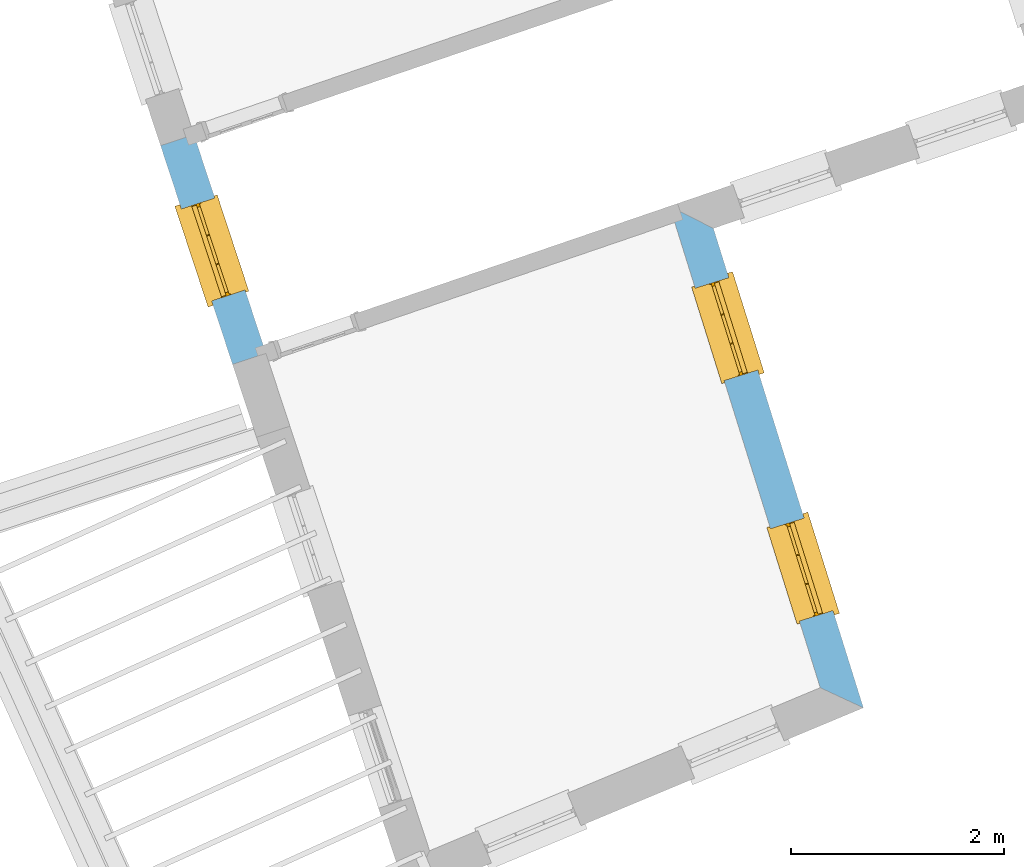
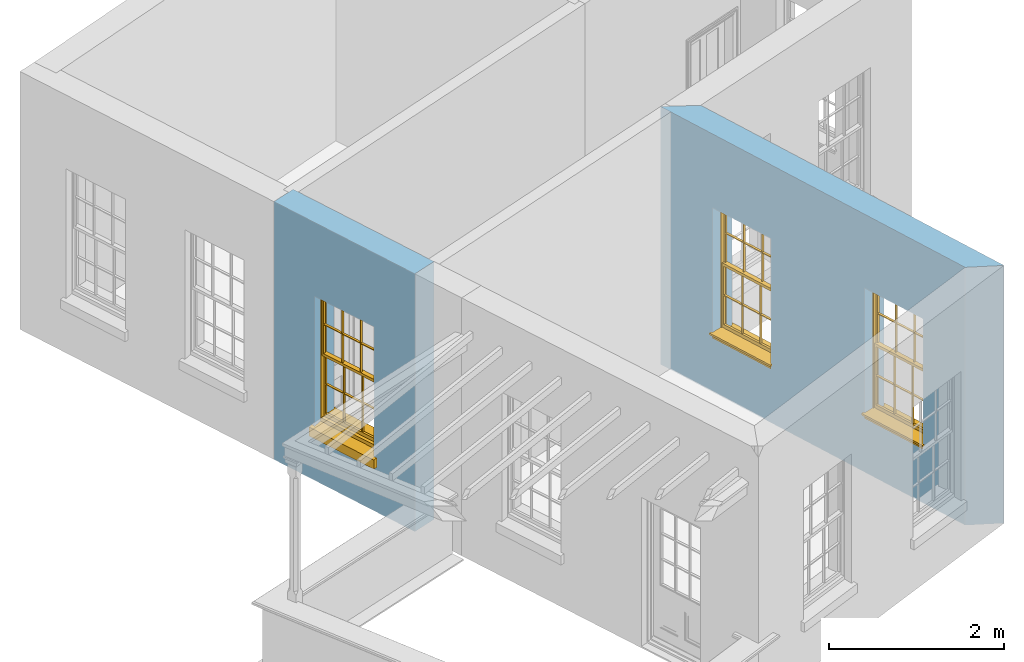
# One storey, part 4 of 10: 3 windows, 3 openings, plus 2 elements that do not belong to this part.
"""IFC2X3 building model written with IfcOpenShell, lengths in metres."""

from ifc_helpers import new_model, si_unit, frame, origin, place, context, subcontext, project, spatial, polyline, outline, extrude, faceted_brep, material, layer, layer_set, layer_usage, element, fill, save


model = new_model("IFC2X3")

# Units and contexts
model_context = context("Model", 3, world=origin())
body_context = subcontext(model_context, "Body", "Model", "MODEL_VIEW")
ifc_project = project(units=[si_unit("PLANEANGLEUNIT", "RADIAN"), si_unit("MASSUNIT", "GRAM", prefix="KILO"), si_unit("FORCEUNIT", "NEWTON", prefix="KILO"), si_unit("LENGTHUNIT", "METRE")], contexts=[model_context])

# Site, building, storey
site_placement = place(None, origin())
site = spatial("IfcSite", under=ifc_project, at=site_placement, CompositionType="ELEMENT")
building_placement = place(None, origin())
building = spatial("IfcBuilding", under=site, at=building_placement, Name="Building plot-2", CompositionType="ELEMENT")
storey_placement = place(None, frame((0.0, 0.0, 4.6)))
storey = spatial("IfcBuildingStorey", under=building, at=storey_placement, Name="Floor 1", CompositionType="ELEMENT", Elevation=4.6)

# Wall, opening, window
ifc_material = material(Name="Masonry")
ifc_layer = layer(ifc_material, 0.33, ventilated=False)
ifc_layer_set = layer_set([ifc_layer], Name="My Wall")
ifc_layer_usage = layer_usage(ifc_layer_set, "AXIS2", "NEGATIVE", 0.08)
wall_1_placement = place(storey_placement, origin())
wall_1 = element("IfcWallStandardCase", 1, at=wall_1_placement, inside=storey, material=ifc_layer_usage, Name="exterior", context=body_context, shape_type="SweptSolid", body=[
    extrude(outline(polyline([(28.7663601729081, 33.4013868683963), (28.4528876869268, 33.2982607294562), (29.1281442502824, 31.2456836062765), (29.4416167362638, 31.3488097452166), (28.7663601729081, 33.4013868683963)])), origin(), (0.0, 0.0, 1.0), 3.6),
])
opening_1_placement = place(storey_placement, frame((0.0, 0.0, 0.75)))
opening_1 = element("IfcOpeningElement", 2, at=opening_1_placement, cuts=wall_1, Name="Opening", ObjectType="Opening", context=body_context, shape_type="SweptSolid", body=[
    extrude(outline(polyline([(28.6483268982478, 32.7041842318709), (28.9327050389614, 31.8397601038618), (29.2461775249427, 31.9428862428019), (28.9617993842291, 32.807310370811), (28.6483268982478, 32.7041842318709)])), origin(), (0.0, 0.0, 1.0), 1.82),
])
window_1_placement = place(storey_placement, frame((28.8858060542942, 32.7823100947043, 0.75), z_axis=(0.0, 0.0, 1.0), x_axis=(0.284378140713624, -0.864424128009084, 0.0)))
window_1 = element("IfcWindow", 3, at=window_1_placement, inside=storey, Name="circulation outside window", OverallHeight=1.82, OverallWidth=0.91, context=body_context, shape_type="Brep", held_by="IfcProductRepresentation", body=[
    faceted_brep([(0.033125, -0.105, 0.975209), (0.01, -0.105, 0.975209), (0.033125, -0.105, 1.376042), (0.876875, -0.105, 0.975209), (0.876875, -0.105, 1.376042), (0.9, -0.105, 0.975209), (0.876875, -0.105, 1.386042), (0.876875, -0.105, 1.786875), (0.9, -0.105, 1.81), (0.033125, -0.105, 1.786875), (0.033125, -0.105, 1.386042), (0.01, -0.105, 1.81), (0.876875, -0.135, 1.376042), (0.876875, -0.135, 0.975209), (0.9, -0.135, 0.937083), (0.033125, -0.135, 1.786875), (0.01, -0.135, 1.81), (0.033125, -0.135, 1.386042), (0.01, -0.135, 0.937083), (0.033125, -0.135, 0.975209), (0.033125, -0.135, 1.376042), (0.876875, -0.135, 1.786875), (0.876875, -0.135, 1.386042), (0.9, -0.135, 1.81), (0.033125, -0.105, 0.937083), (0.01, -0.105, 0.937083), (0.033125, -0.105, 0.53625), (0.876875, -0.105, 0.937083), (0.876875, -0.105, 0.53625), (0.9, -0.105, 0.937083), (0.876875, -0.105, 0.52625), (0.876875, -0.105, 0.125417), (0.9, -0.105, 0.077167), (0.033125, -0.105, 0.125417), (0.033125, -0.105, 0.52625), (0.01, -0.105, 0.077167), (-0.0425, -0.25, 0.01), (-0.0425, -0.3, 0.001667), (0.0, -0.25, 0.01), (0.9525, -0.25, 0.01), (0.91, -0.25, 0.01), (0.9525, -0.3, 0.001667), (-0.02, 0.08, 0.077167), (0.0, 0.08, 0.077167), (-0.02, 0.11, 0.077167), (0.0, -0.06, 0.077167), (0.01, -0.06, 0.077167), (0.91, -0.06, 0.077167), (0.91, 0.08, 0.077167), (0.9, -0.06, 0.077167), (0.93, 0.08, 0.077167), (0.93, 0.11, 0.077167), (0.01, -0.075, 0.975209), (0.9, -0.075, 0.975209), (0.876875, -0.075, 0.125417), (0.876875, -0.075, 0.52625), (0.9, -0.075, 0.077167), (0.876875, -0.075, 0.53625), (0.876875, -0.075, 0.937083), (0.033125, -0.075, 0.125417), (0.01, -0.075, 0.077167), (0.033125, -0.075, 0.52625), (0.033125, -0.075, 0.937083), (0.033125, -0.075, 0.53625), (-0.02, 0.08, 0.052167), (-0.02, 0.11, 0.052167), (0.93, 0.11, 0.052167), (0.93, 0.08, 0.052167), (0.91, 0.08, 0.052167), (0.0, 0.08, 0.052167), (0.91, -0.15, 0.026667), (0.0, -0.15, 0.026667), (-0.0425, -0.3, -0.123333), (0.9525, -0.3, -0.123333), (-0.0425, -0.25, -0.123333), (0.9525, -0.25, -0.123333), (0.01, -0.06, 1.81), (0.9, -0.06, 1.81), (0.0, -0.06, 1.82), (0.91, -0.06, 1.82), (0.01, -0.15, 0.077167), (0.9, -0.15, 0.077167), (0.592292, -0.105, 0.125417), (0.592292, -0.075, 0.125417), (0.317708, -0.075, 0.125417), (0.317708, -0.105, 0.125417), (0.592292, -0.105, 0.53625), (0.317708, -0.105, 0.53625), (0.317708, -0.105, 0.52625), (0.592292, -0.105, 0.52625), (0.592292, -0.075, 0.53625), (0.317708, -0.075, 0.53625), (0.592292, -0.135, 1.386042), (0.592292, -0.105, 1.386042), (0.317708, -0.105, 1.386042), (0.317708, -0.135, 1.386042), (0.317708, -0.135, 1.376042), (0.592292, -0.135, 1.376042), (0.317708, -0.105, 1.376042), (0.592292, -0.105, 1.376042), (0.602292, -0.135, 1.376042), (0.592292, -0.135, 0.975209), (0.602292, -0.135, 0.975209), (0.602292, -0.105, 0.975209), (0.592292, -0.105, 0.975209), (0.602292, -0.105, 1.376042), (0.602292, -0.075, 0.53625), (0.602292, -0.105, 0.53625), (0.317708, -0.075, 0.52625), (0.307708, -0.075, 0.125417), (0.307708, -0.075, 0.52625), (0.602292, -0.075, 0.52625), (0.602292, -0.075, 0.125417), (0.592292, -0.075, 0.52625), (0.307708, -0.075, 0.53625), (0.317708, -0.075, 0.937083), (0.307708, -0.075, 0.937083), (0.602292, -0.075, 0.937083), (0.592292, -0.075, 0.937083), (0.307708, -0.105, 0.52625), (0.307708, -0.105, 0.125417), (0.307708, -0.105, 0.53625), (0.307708, -0.105, 0.937083), (0.592292, -0.105, 0.937083), (0.317708, -0.105, 0.937083), (0.602292, -0.105, 0.937083), (0.602292, -0.105, 0.52625), (0.602292, -0.105, 0.125417), (0.307708, -0.135, 1.386042), (0.307708, -0.135, 1.376042), (0.307708, -0.135, 0.975209), (0.317708, -0.135, 0.975209), (0.317708, -0.135, 1.786875), (0.307708, -0.135, 1.786875), (0.602292, -0.135, 1.786875), (0.592292, -0.135, 1.786875), (0.602292, -0.135, 1.386042), (0.602292, -0.105, 1.386042), (0.307708, -0.105, 1.386042), (0.307708, -0.105, 1.786875), (0.317708, -0.105, 1.786875), (0.592292, -0.105, 1.786875), (0.602292, -0.105, 1.786875), (0.307708, -0.105, 1.376042), (0.317708, -0.105, 0.975209), (0.307708, -0.105, 0.975209), (0.91, -0.15, 1.82), (0.9, -0.15, 1.81), (0.01, -0.15, 1.81), (0.0, -0.15, 1.82), (0.91, -0.25, 0.0), (0.0, -0.25, 0.0), (0.91, 0.08, 0.0), (0.0, 0.08, 0.0)], [[[0, 1, 2]], [[3, 4, 5]], [[6, 7, 8]], [[9, 10, 11]], [[12, 13, 14]], [[15, 16, 17]], [[18, 19, 20]], [[21, 22, 23]], [[24, 25, 26]], [[27, 28, 29]], [[30, 31, 32]], [[33, 34, 35]], [[14, 27, 29]], [[25, 24, 18]], [[36, 37, 38]], [[39, 40, 41]], [[42, 43, 44]], [[45, 46, 43]], [[47, 48, 49]], [[50, 51, 48]], [[1, 0, 52]], [[5, 53, 3]], [[54, 55, 56]], [[57, 58, 53]], [[59, 60, 61]], [[62, 63, 52]], [[48, 43, 46, 49]], [[51, 44, 43, 48]], [[64, 42, 44, 65]], [[65, 44, 51, 66]], [[66, 51, 50, 67]], [[65, 66, 68, 69]], [[60, 56, 49, 46]], [[70, 71, 38, 40]], [[37, 41, 40, 38]], [[37, 72, 73, 41]], [[74, 75, 73, 72]], [[8, 11, 76, 77]], [[76, 78, 79, 77]], [[32, 35, 80, 81]], [[81, 80, 71, 70]], [[82, 83, 84, 85]], [[86, 87, 88, 89]], [[86, 90, 91, 87]], [[92, 93, 94, 95]], [[92, 95, 96, 97]], [[96, 98, 99, 97]], [[100, 97, 101, 102]], [[103, 104, 99, 105]], [[97, 99, 104, 101]], [[102, 103, 105, 100]], [[28, 57, 106, 107]], [[108, 84, 109, 110]], [[111, 112, 83, 113]], [[114, 110, 61, 63]], [[90, 113, 108, 91]], [[115, 91, 114, 116]], [[117, 106, 90, 118]], [[111, 106, 57, 55]], [[119, 110, 109, 120]], [[34, 61, 110, 119]], [[89, 113, 83, 82]], [[88, 108, 113, 89]], [[85, 84, 108, 88]], [[121, 114, 63, 26]], [[122, 116, 114, 121]], [[123, 118, 90, 86]], [[87, 91, 115, 124]], [[107, 106, 117, 125]], [[126, 111, 55, 30]], [[127, 112, 111, 126]], [[126, 30, 28, 107]], [[88, 119, 120, 85]], [[126, 89, 82, 127]], [[125, 123, 86, 107]], [[121, 26, 34, 119]], [[124, 122, 121, 87]], [[128, 17, 20, 129]], [[96, 129, 130, 131]], [[132, 133, 128, 95]], [[134, 135, 92, 136]], [[100, 12, 22, 136]], [[137, 6, 4, 105]], [[94, 138, 139, 140]], [[137, 93, 141, 142]], [[99, 98, 94, 93]], [[143, 2, 10, 138]], [[144, 145, 143, 98]], [[129, 143, 145, 130]], [[20, 2, 143, 129]], [[131, 144, 98, 96]], [[128, 138, 10, 17]], [[133, 139, 138, 128]], [[135, 141, 93, 92]], [[95, 94, 140, 132]], [[22, 6, 137, 136]], [[136, 137, 142, 134]], [[100, 105, 4, 12]], [[107, 86, 89, 126]], [[106, 111, 113, 90]], [[91, 108, 110, 114]], [[87, 121, 119, 88]], [[97, 100, 136, 92]], [[129, 96, 95, 128]], [[98, 143, 138, 94]], [[105, 99, 93, 137]], [[131, 101, 104, 144]], [[124, 115, 118, 123]], [[132, 140, 141, 135]], [[120, 109, 59, 33]], [[15, 9, 139, 133]], [[134, 142, 7, 21]], [[31, 54, 112, 127]], [[36, 74, 72, 37]], [[39, 41, 73, 75]], [[18, 14, 101, 131]], [[23, 16, 132, 135]], [[83, 56, 60, 84]], [[52, 53, 118, 115]], [[53, 52, 144, 104]], [[11, 8, 141, 140]], [[14, 18, 124, 123]], [[2, 1, 11, 10]], [[8, 5, 4, 6]], [[57, 53, 56, 55]], [[60, 52, 63, 61]], [[26, 25, 35, 34]], [[32, 29, 28, 30]], [[14, 23, 22, 12]], [[18, 20, 17, 16]], [[19, 0, 2, 20]], [[17, 10, 9, 15]], [[12, 4, 3, 13]], [[21, 7, 6, 22]], [[27, 58, 57, 28]], [[30, 55, 54, 31]], [[33, 59, 61, 34]], [[26, 63, 62, 24]], [[5, 8, 77, 53]], [[76, 11, 1, 52]], [[46, 45, 78, 76]], [[49, 77, 79, 47]], [[70, 146, 147, 81]], [[71, 80, 148, 149]], [[19, 130, 145, 0]], [[102, 13, 3, 103]], [[116, 122, 24, 62]], [[29, 32, 81, 14]], [[80, 35, 25, 18]], [[60, 46, 76, 52]], [[77, 49, 56, 53]], [[23, 14, 81, 147]], [[16, 148, 80, 18]], [[35, 85, 120]], [[120, 33, 35]], [[127, 82, 32]], [[32, 31, 127]], [[32, 82, 85, 35]], [[102, 101, 14]], [[14, 13, 102]], [[18, 131, 130]], [[130, 19, 18]], [[134, 21, 23]], [[23, 135, 134]], [[16, 15, 133]], [[133, 132, 16]], [[11, 140, 139]], [[139, 9, 11]], [[142, 141, 8]], [[8, 7, 142]], [[23, 147, 148, 16]], [[146, 149, 148, 147]], [[52, 115, 116]], [[116, 62, 52]], [[118, 53, 117]], [[58, 117, 53]], [[27, 125, 117, 58]], [[56, 83, 112]], [[112, 54, 56]], [[109, 84, 60]], [[60, 59, 109]], [[125, 27, 14]], [[14, 123, 125]], [[122, 124, 18]], [[18, 24, 122]], [[145, 144, 52]], [[52, 0, 145]], [[103, 3, 53]], [[53, 104, 103]], [[79, 78, 149, 146]], [[78, 45, 71, 149]], [[146, 70, 47, 79]], [[150, 75, 74, 151]], [[68, 66, 67]], [[48, 68, 67, 50]], [[69, 64, 65]], [[42, 64, 69, 43]], [[69, 68, 152, 153]], [[70, 68, 48, 47]], [[150, 152, 68, 70]], [[43, 69, 71, 45]], [[69, 153, 151, 71]], [[152, 150, 151, 153]], [[38, 151, 74, 36]], [[71, 151, 38]], [[39, 75, 150, 40]], [[40, 150, 70]]]),
])
fill(opening_1, window_1)

# Wall, openings, windows
wall_2_placement = place(storey_placement, origin())
wall_2 = element("IfcWallStandardCase", 4, at=wall_2_placement, inside=storey, material=ifc_layer_usage, Name="exterior", context=body_context, shape_type="SweptSolid", body=[
    extrude(outline(polyline([(34.6434756954392, 28.211451652365), (35.0482793359076, 28.0227845246247), (33.6407893243681, 32.5213803227765), (33.2298586094676, 32.7296307023118), (34.6434756954392, 28.211451652365)])), origin(), (0.0, 0.0, 1.0), 3.6),
])
opening_2_placement = place(storey_placement, frame((0.0, 0.0, 0.75)))
opening_2 = element("IfcOpeningElement", 5, at=opening_2_placement, cuts=wall_2, Name="Opening", ObjectType="Opening", context=body_context, shape_type="SweptSolid", body=[
    extrude(outline(polyline([(34.763034359332, 28.9344797001121), (34.4913088580484, 29.8029641570554), (34.1763639450909, 29.7044263379086), (34.4480894463745, 28.8359418809653), (34.763034359332, 28.9344797001121)])), origin(), (0.0, 0.0, 1.0), 1.82),
])
opening_3_placement = place(storey_placement, frame((0.0, 0.0, 0.75)))
opening_3 = element("IfcOpeningElement", 6, at=opening_3_placement, cuts=wall_2, Name="Opening", ObjectType="Opening", context=body_context, shape_type="SweptSolid", body=[
    extrude(outline(polyline([(34.0569684920349, 31.1911954975952), (33.7852429907513, 32.0596799545385), (33.4702980777938, 31.9611421353917), (33.7420235790774, 31.0926576784484), (34.0569684920349, 31.1911954975952)])), origin(), (0.0, 0.0, 1.0), 1.82),
])
window_2_placement = place(storey_placement, frame((34.5244397283036, 28.8598298371221, 0.75), z_axis=(0.0, 0.0, 1.0), x_axis=(-0.271725501283605, 0.868484456943346, 0.0)))
window_2 = element("IfcWindow", 7, at=window_2_placement, inside=storey, Name="bedroom outside window", OverallHeight=1.82, OverallWidth=0.91, context=body_context, shape_type="Brep", held_by="IfcProductRepresentation", body=[
    faceted_brep([(0.033125, -0.105, 0.975209), (0.01, -0.105, 0.975209), (0.033125, -0.105, 1.376042), (0.876875, -0.105, 0.975209), (0.876875, -0.105, 1.376042), (0.9, -0.105, 0.975209), (0.876875, -0.105, 1.386042), (0.876875, -0.105, 1.786875), (0.9, -0.105, 1.81), (0.033125, -0.105, 1.786875), (0.033125, -0.105, 1.386042), (0.01, -0.105, 1.81), (0.876875, -0.135, 1.376042), (0.876875, -0.135, 0.975209), (0.9, -0.135, 0.937083), (0.033125, -0.135, 1.786875), (0.01, -0.135, 1.81), (0.033125, -0.135, 1.386042), (0.01, -0.135, 0.937083), (0.033125, -0.135, 0.975209), (0.033125, -0.135, 1.376042), (0.876875, -0.135, 1.786875), (0.876875, -0.135, 1.386042), (0.9, -0.135, 1.81), (0.033125, -0.105, 0.937083), (0.01, -0.105, 0.937083), (0.033125, -0.105, 0.53625), (0.876875, -0.105, 0.937083), (0.876875, -0.105, 0.53625), (0.9, -0.105, 0.937083), (0.876875, -0.105, 0.52625), (0.876875, -0.105, 0.125417), (0.9, -0.105, 0.077167), (0.033125, -0.105, 0.125417), (0.033125, -0.105, 0.52625), (0.01, -0.105, 0.077167), (-0.0425, -0.25, 0.01), (-0.0425, -0.3, 0.001667), (0.0, -0.25, 0.01), (0.9525, -0.25, 0.01), (0.91, -0.25, 0.01), (0.9525, -0.3, 0.001667), (-0.02, 0.08, 0.077167), (0.0, 0.08, 0.077167), (-0.02, 0.11, 0.077167), (0.0, -0.06, 0.077167), (0.01, -0.06, 0.077167), (0.91, -0.06, 0.077167), (0.91, 0.08, 0.077167), (0.9, -0.06, 0.077167), (0.93, 0.08, 0.077167), (0.93, 0.11, 0.077167), (0.01, -0.075, 0.975209), (0.9, -0.075, 0.975209), (0.876875, -0.075, 0.125417), (0.876875, -0.075, 0.52625), (0.9, -0.075, 0.077167), (0.876875, -0.075, 0.53625), (0.876875, -0.075, 0.937083), (0.033125, -0.075, 0.125417), (0.01, -0.075, 0.077167), (0.033125, -0.075, 0.52625), (0.033125, -0.075, 0.937083), (0.033125, -0.075, 0.53625), (-0.02, 0.08, 0.052167), (-0.02, 0.11, 0.052167), (0.93, 0.11, 0.052167), (0.93, 0.08, 0.052167), (0.91, 0.08, 0.052167), (0.0, 0.08, 0.052167), (0.91, -0.15, 0.026667), (0.0, -0.15, 0.026667), (-0.0425, -0.3, -0.123333), (0.9525, -0.3, -0.123333), (-0.0425, -0.25, -0.123333), (0.9525, -0.25, -0.123333), (0.01, -0.06, 1.81), (0.9, -0.06, 1.81), (0.0, -0.06, 1.82), (0.91, -0.06, 1.82), (0.01, -0.15, 0.077167), (0.9, -0.15, 0.077167), (0.592292, -0.105, 0.125417), (0.592292, -0.075, 0.125417), (0.317708, -0.075, 0.125417), (0.317708, -0.105, 0.125417), (0.592292, -0.105, 0.53625), (0.317708, -0.105, 0.53625), (0.317708, -0.105, 0.52625), (0.592292, -0.105, 0.52625), (0.592292, -0.075, 0.53625), (0.317708, -0.075, 0.53625), (0.592292, -0.135, 1.386042), (0.592292, -0.105, 1.386042), (0.317708, -0.105, 1.386042), (0.317708, -0.135, 1.386042), (0.317708, -0.135, 1.376042), (0.592292, -0.135, 1.376042), (0.317708, -0.105, 1.376042), (0.592292, -0.105, 1.376042), (0.602292, -0.135, 1.376042), (0.592292, -0.135, 0.975209), (0.602292, -0.135, 0.975209), (0.602292, -0.105, 0.975209), (0.592292, -0.105, 0.975209), (0.602292, -0.105, 1.376042), (0.602292, -0.075, 0.53625), (0.602292, -0.105, 0.53625), (0.317708, -0.075, 0.52625), (0.307708, -0.075, 0.125417), (0.307708, -0.075, 0.52625), (0.602292, -0.075, 0.52625), (0.602292, -0.075, 0.125417), (0.592292, -0.075, 0.52625), (0.307708, -0.075, 0.53625), (0.317708, -0.075, 0.937083), (0.307708, -0.075, 0.937083), (0.602292, -0.075, 0.937083), (0.592292, -0.075, 0.937083), (0.307708, -0.105, 0.52625), (0.307708, -0.105, 0.125417), (0.307708, -0.105, 0.53625), (0.307708, -0.105, 0.937083), (0.592292, -0.105, 0.937083), (0.317708, -0.105, 0.937083), (0.602292, -0.105, 0.937083), (0.602292, -0.105, 0.52625), (0.602292, -0.105, 0.125417), (0.307708, -0.135, 1.386042), (0.307708, -0.135, 1.376042), (0.307708, -0.135, 0.975209), (0.317708, -0.135, 0.975209), (0.317708, -0.135, 1.786875), (0.307708, -0.135, 1.786875), (0.602292, -0.135, 1.786875), (0.592292, -0.135, 1.786875), (0.602292, -0.135, 1.386042), (0.602292, -0.105, 1.386042), (0.307708, -0.105, 1.386042), (0.307708, -0.105, 1.786875), (0.317708, -0.105, 1.786875), (0.592292, -0.105, 1.786875), (0.602292, -0.105, 1.786875), (0.307708, -0.105, 1.376042), (0.317708, -0.105, 0.975209), (0.307708, -0.105, 0.975209), (0.91, -0.15, 1.82), (0.9, -0.15, 1.81), (0.01, -0.15, 1.81), (0.0, -0.15, 1.82), (0.91, -0.25, 0.0), (0.0, -0.25, 0.0), (0.91, 0.08, 0.0), (0.0, 0.08, 0.0)], [[[0, 1, 2]], [[3, 4, 5]], [[6, 7, 8]], [[9, 10, 11]], [[12, 13, 14]], [[15, 16, 17]], [[18, 19, 20]], [[21, 22, 23]], [[24, 25, 26]], [[27, 28, 29]], [[30, 31, 32]], [[33, 34, 35]], [[14, 27, 29]], [[25, 24, 18]], [[36, 37, 38]], [[39, 40, 41]], [[42, 43, 44]], [[45, 46, 43]], [[47, 48, 49]], [[50, 51, 48]], [[1, 0, 52]], [[5, 53, 3]], [[54, 55, 56]], [[57, 58, 53]], [[59, 60, 61]], [[62, 63, 52]], [[48, 43, 46, 49]], [[51, 44, 43, 48]], [[64, 42, 44, 65]], [[65, 44, 51, 66]], [[66, 51, 50, 67]], [[65, 66, 68, 69]], [[60, 56, 49, 46]], [[70, 71, 38, 40]], [[37, 41, 40, 38]], [[37, 72, 73, 41]], [[74, 75, 73, 72]], [[8, 11, 76, 77]], [[76, 78, 79, 77]], [[32, 35, 80, 81]], [[81, 80, 71, 70]], [[82, 83, 84, 85]], [[86, 87, 88, 89]], [[86, 90, 91, 87]], [[92, 93, 94, 95]], [[92, 95, 96, 97]], [[96, 98, 99, 97]], [[100, 97, 101, 102]], [[103, 104, 99, 105]], [[97, 99, 104, 101]], [[102, 103, 105, 100]], [[28, 57, 106, 107]], [[108, 84, 109, 110]], [[111, 112, 83, 113]], [[114, 110, 61, 63]], [[90, 113, 108, 91]], [[115, 91, 114, 116]], [[117, 106, 90, 118]], [[111, 106, 57, 55]], [[119, 110, 109, 120]], [[34, 61, 110, 119]], [[89, 113, 83, 82]], [[88, 108, 113, 89]], [[85, 84, 108, 88]], [[121, 114, 63, 26]], [[122, 116, 114, 121]], [[123, 118, 90, 86]], [[87, 91, 115, 124]], [[107, 106, 117, 125]], [[126, 111, 55, 30]], [[127, 112, 111, 126]], [[126, 30, 28, 107]], [[88, 119, 120, 85]], [[126, 89, 82, 127]], [[125, 123, 86, 107]], [[121, 26, 34, 119]], [[124, 122, 121, 87]], [[128, 17, 20, 129]], [[96, 129, 130, 131]], [[132, 133, 128, 95]], [[134, 135, 92, 136]], [[100, 12, 22, 136]], [[137, 6, 4, 105]], [[94, 138, 139, 140]], [[137, 93, 141, 142]], [[99, 98, 94, 93]], [[143, 2, 10, 138]], [[144, 145, 143, 98]], [[129, 143, 145, 130]], [[20, 2, 143, 129]], [[131, 144, 98, 96]], [[128, 138, 10, 17]], [[133, 139, 138, 128]], [[135, 141, 93, 92]], [[95, 94, 140, 132]], [[22, 6, 137, 136]], [[136, 137, 142, 134]], [[100, 105, 4, 12]], [[107, 86, 89, 126]], [[106, 111, 113, 90]], [[91, 108, 110, 114]], [[87, 121, 119, 88]], [[97, 100, 136, 92]], [[129, 96, 95, 128]], [[98, 143, 138, 94]], [[105, 99, 93, 137]], [[131, 101, 104, 144]], [[124, 115, 118, 123]], [[132, 140, 141, 135]], [[120, 109, 59, 33]], [[15, 9, 139, 133]], [[134, 142, 7, 21]], [[31, 54, 112, 127]], [[36, 74, 72, 37]], [[39, 41, 73, 75]], [[18, 14, 101, 131]], [[23, 16, 132, 135]], [[83, 56, 60, 84]], [[52, 53, 118, 115]], [[53, 52, 144, 104]], [[11, 8, 141, 140]], [[14, 18, 124, 123]], [[2, 1, 11, 10]], [[8, 5, 4, 6]], [[57, 53, 56, 55]], [[60, 52, 63, 61]], [[26, 25, 35, 34]], [[32, 29, 28, 30]], [[14, 23, 22, 12]], [[18, 20, 17, 16]], [[19, 0, 2, 20]], [[17, 10, 9, 15]], [[12, 4, 3, 13]], [[21, 7, 6, 22]], [[27, 58, 57, 28]], [[30, 55, 54, 31]], [[33, 59, 61, 34]], [[26, 63, 62, 24]], [[5, 8, 77, 53]], [[76, 11, 1, 52]], [[46, 45, 78, 76]], [[49, 77, 79, 47]], [[70, 146, 147, 81]], [[71, 80, 148, 149]], [[19, 130, 145, 0]], [[102, 13, 3, 103]], [[116, 122, 24, 62]], [[29, 32, 81, 14]], [[80, 35, 25, 18]], [[60, 46, 76, 52]], [[77, 49, 56, 53]], [[23, 14, 81, 147]], [[16, 148, 80, 18]], [[35, 85, 120]], [[120, 33, 35]], [[127, 82, 32]], [[32, 31, 127]], [[32, 82, 85, 35]], [[102, 101, 14]], [[14, 13, 102]], [[18, 131, 130]], [[130, 19, 18]], [[134, 21, 23]], [[23, 135, 134]], [[16, 15, 133]], [[133, 132, 16]], [[11, 140, 139]], [[139, 9, 11]], [[142, 141, 8]], [[8, 7, 142]], [[23, 147, 148, 16]], [[146, 149, 148, 147]], [[52, 115, 116]], [[116, 62, 52]], [[118, 53, 117]], [[58, 117, 53]], [[27, 125, 117, 58]], [[56, 83, 112]], [[112, 54, 56]], [[109, 84, 60]], [[60, 59, 109]], [[125, 27, 14]], [[14, 123, 125]], [[122, 124, 18]], [[18, 24, 122]], [[145, 144, 52]], [[52, 0, 145]], [[103, 3, 53]], [[53, 104, 103]], [[79, 78, 149, 146]], [[78, 45, 71, 149]], [[146, 70, 47, 79]], [[150, 75, 74, 151]], [[68, 66, 67]], [[48, 68, 67, 50]], [[69, 64, 65]], [[42, 64, 69, 43]], [[69, 68, 152, 153]], [[70, 68, 48, 47]], [[150, 152, 68, 70]], [[43, 69, 71, 45]], [[69, 153, 151, 71]], [[152, 150, 151, 153]], [[38, 151, 74, 36]], [[71, 151, 38]], [[39, 75, 150, 40]], [[40, 150, 70]]]),
])
fill(opening_2, window_2)
window_3_placement = place(storey_placement, frame((33.8183738610065, 31.1165456346052, 0.75), z_axis=(0.0, 0.0, 1.0), x_axis=(-0.271725501283605, 0.868484456943346, 0.0)))
window_3 = element("IfcWindow", 8, at=window_3_placement, inside=storey, Name="bedroom outside window", OverallHeight=1.82, OverallWidth=0.91, context=body_context, shape_type="Brep", held_by="IfcProductRepresentation", body=[
    faceted_brep([(0.033125, -0.105, 0.975209), (0.01, -0.105, 0.975209), (0.033125, -0.105, 1.376042), (0.876875, -0.105, 0.975209), (0.876875, -0.105, 1.376042), (0.9, -0.105, 0.975209), (0.876875, -0.105, 1.386042), (0.876875, -0.105, 1.786875), (0.9, -0.105, 1.81), (0.033125, -0.105, 1.786875), (0.033125, -0.105, 1.386042), (0.01, -0.105, 1.81), (0.876875, -0.135, 1.376042), (0.876875, -0.135, 0.975209), (0.9, -0.135, 0.937083), (0.033125, -0.135, 1.786875), (0.01, -0.135, 1.81), (0.033125, -0.135, 1.386042), (0.01, -0.135, 0.937083), (0.033125, -0.135, 0.975209), (0.033125, -0.135, 1.376042), (0.876875, -0.135, 1.786875), (0.876875, -0.135, 1.386042), (0.9, -0.135, 1.81), (0.033125, -0.105, 0.937083), (0.01, -0.105, 0.937083), (0.033125, -0.105, 0.53625), (0.876875, -0.105, 0.937083), (0.876875, -0.105, 0.53625), (0.9, -0.105, 0.937083), (0.876875, -0.105, 0.52625), (0.876875, -0.105, 0.125417), (0.9, -0.105, 0.077167), (0.033125, -0.105, 0.125417), (0.033125, -0.105, 0.52625), (0.01, -0.105, 0.077167), (-0.0425, -0.25, 0.01), (-0.0425, -0.3, 0.001667), (0.0, -0.25, 0.01), (0.9525, -0.25, 0.01), (0.91, -0.25, 0.01), (0.9525, -0.3, 0.001667), (-0.02, 0.08, 0.077167), (0.0, 0.08, 0.077167), (-0.02, 0.11, 0.077167), (0.0, -0.06, 0.077167), (0.01, -0.06, 0.077167), (0.91, -0.06, 0.077167), (0.91, 0.08, 0.077167), (0.9, -0.06, 0.077167), (0.93, 0.08, 0.077167), (0.93, 0.11, 0.077167), (0.01, -0.075, 0.975209), (0.9, -0.075, 0.975209), (0.876875, -0.075, 0.125417), (0.876875, -0.075, 0.52625), (0.9, -0.075, 0.077167), (0.876875, -0.075, 0.53625), (0.876875, -0.075, 0.937083), (0.033125, -0.075, 0.125417), (0.01, -0.075, 0.077167), (0.033125, -0.075, 0.52625), (0.033125, -0.075, 0.937083), (0.033125, -0.075, 0.53625), (-0.02, 0.08, 0.052167), (-0.02, 0.11, 0.052167), (0.93, 0.11, 0.052167), (0.93, 0.08, 0.052167), (0.91, 0.08, 0.052167), (0.0, 0.08, 0.052167), (0.91, -0.15, 0.026667), (0.0, -0.15, 0.026667), (-0.0425, -0.3, -0.123333), (0.9525, -0.3, -0.123333), (-0.0425, -0.25, -0.123333), (0.9525, -0.25, -0.123333), (0.01, -0.06, 1.81), (0.9, -0.06, 1.81), (0.0, -0.06, 1.82), (0.91, -0.06, 1.82), (0.01, -0.15, 0.077167), (0.9, -0.15, 0.077167), (0.592292, -0.105, 0.125417), (0.592292, -0.075, 0.125417), (0.317708, -0.075, 0.125417), (0.317708, -0.105, 0.125417), (0.592292, -0.105, 0.53625), (0.317708, -0.105, 0.53625), (0.317708, -0.105, 0.52625), (0.592292, -0.105, 0.52625), (0.592292, -0.075, 0.53625), (0.317708, -0.075, 0.53625), (0.592292, -0.135, 1.386042), (0.592292, -0.105, 1.386042), (0.317708, -0.105, 1.386042), (0.317708, -0.135, 1.386042), (0.317708, -0.135, 1.376042), (0.592292, -0.135, 1.376042), (0.317708, -0.105, 1.376042), (0.592292, -0.105, 1.376042), (0.602292, -0.135, 1.376042), (0.592292, -0.135, 0.975209), (0.602292, -0.135, 0.975209), (0.602292, -0.105, 0.975209), (0.592292, -0.105, 0.975209), (0.602292, -0.105, 1.376042), (0.602292, -0.075, 0.53625), (0.602292, -0.105, 0.53625), (0.317708, -0.075, 0.52625), (0.307708, -0.075, 0.125417), (0.307708, -0.075, 0.52625), (0.602292, -0.075, 0.52625), (0.602292, -0.075, 0.125417), (0.592292, -0.075, 0.52625), (0.307708, -0.075, 0.53625), (0.317708, -0.075, 0.937083), (0.307708, -0.075, 0.937083), (0.602292, -0.075, 0.937083), (0.592292, -0.075, 0.937083), (0.307708, -0.105, 0.52625), (0.307708, -0.105, 0.125417), (0.307708, -0.105, 0.53625), (0.307708, -0.105, 0.937083), (0.592292, -0.105, 0.937083), (0.317708, -0.105, 0.937083), (0.602292, -0.105, 0.937083), (0.602292, -0.105, 0.52625), (0.602292, -0.105, 0.125417), (0.307708, -0.135, 1.386042), (0.307708, -0.135, 1.376042), (0.307708, -0.135, 0.975209), (0.317708, -0.135, 0.975209), (0.317708, -0.135, 1.786875), (0.307708, -0.135, 1.786875), (0.602292, -0.135, 1.786875), (0.592292, -0.135, 1.786875), (0.602292, -0.135, 1.386042), (0.602292, -0.105, 1.386042), (0.307708, -0.105, 1.386042), (0.307708, -0.105, 1.786875), (0.317708, -0.105, 1.786875), (0.592292, -0.105, 1.786875), (0.602292, -0.105, 1.786875), (0.307708, -0.105, 1.376042), (0.317708, -0.105, 0.975209), (0.307708, -0.105, 0.975209), (0.91, -0.15, 1.82), (0.9, -0.15, 1.81), (0.01, -0.15, 1.81), (0.0, -0.15, 1.82), (0.91, -0.25, 0.0), (0.0, -0.25, 0.0), (0.91, 0.08, 0.0), (0.0, 0.08, 0.0)], [[[0, 1, 2]], [[3, 4, 5]], [[6, 7, 8]], [[9, 10, 11]], [[12, 13, 14]], [[15, 16, 17]], [[18, 19, 20]], [[21, 22, 23]], [[24, 25, 26]], [[27, 28, 29]], [[30, 31, 32]], [[33, 34, 35]], [[14, 27, 29]], [[25, 24, 18]], [[36, 37, 38]], [[39, 40, 41]], [[42, 43, 44]], [[45, 46, 43]], [[47, 48, 49]], [[50, 51, 48]], [[1, 0, 52]], [[5, 53, 3]], [[54, 55, 56]], [[57, 58, 53]], [[59, 60, 61]], [[62, 63, 52]], [[48, 43, 46, 49]], [[51, 44, 43, 48]], [[64, 42, 44, 65]], [[65, 44, 51, 66]], [[66, 51, 50, 67]], [[65, 66, 68, 69]], [[60, 56, 49, 46]], [[70, 71, 38, 40]], [[37, 41, 40, 38]], [[37, 72, 73, 41]], [[74, 75, 73, 72]], [[8, 11, 76, 77]], [[76, 78, 79, 77]], [[32, 35, 80, 81]], [[81, 80, 71, 70]], [[82, 83, 84, 85]], [[86, 87, 88, 89]], [[86, 90, 91, 87]], [[92, 93, 94, 95]], [[92, 95, 96, 97]], [[96, 98, 99, 97]], [[100, 97, 101, 102]], [[103, 104, 99, 105]], [[97, 99, 104, 101]], [[102, 103, 105, 100]], [[28, 57, 106, 107]], [[108, 84, 109, 110]], [[111, 112, 83, 113]], [[114, 110, 61, 63]], [[90, 113, 108, 91]], [[115, 91, 114, 116]], [[117, 106, 90, 118]], [[111, 106, 57, 55]], [[119, 110, 109, 120]], [[34, 61, 110, 119]], [[89, 113, 83, 82]], [[88, 108, 113, 89]], [[85, 84, 108, 88]], [[121, 114, 63, 26]], [[122, 116, 114, 121]], [[123, 118, 90, 86]], [[87, 91, 115, 124]], [[107, 106, 117, 125]], [[126, 111, 55, 30]], [[127, 112, 111, 126]], [[126, 30, 28, 107]], [[88, 119, 120, 85]], [[126, 89, 82, 127]], [[125, 123, 86, 107]], [[121, 26, 34, 119]], [[124, 122, 121, 87]], [[128, 17, 20, 129]], [[96, 129, 130, 131]], [[132, 133, 128, 95]], [[134, 135, 92, 136]], [[100, 12, 22, 136]], [[137, 6, 4, 105]], [[94, 138, 139, 140]], [[137, 93, 141, 142]], [[99, 98, 94, 93]], [[143, 2, 10, 138]], [[144, 145, 143, 98]], [[129, 143, 145, 130]], [[20, 2, 143, 129]], [[131, 144, 98, 96]], [[128, 138, 10, 17]], [[133, 139, 138, 128]], [[135, 141, 93, 92]], [[95, 94, 140, 132]], [[22, 6, 137, 136]], [[136, 137, 142, 134]], [[100, 105, 4, 12]], [[107, 86, 89, 126]], [[106, 111, 113, 90]], [[91, 108, 110, 114]], [[87, 121, 119, 88]], [[97, 100, 136, 92]], [[129, 96, 95, 128]], [[98, 143, 138, 94]], [[105, 99, 93, 137]], [[131, 101, 104, 144]], [[124, 115, 118, 123]], [[132, 140, 141, 135]], [[120, 109, 59, 33]], [[15, 9, 139, 133]], [[134, 142, 7, 21]], [[31, 54, 112, 127]], [[36, 74, 72, 37]], [[39, 41, 73, 75]], [[18, 14, 101, 131]], [[23, 16, 132, 135]], [[83, 56, 60, 84]], [[52, 53, 118, 115]], [[53, 52, 144, 104]], [[11, 8, 141, 140]], [[14, 18, 124, 123]], [[2, 1, 11, 10]], [[8, 5, 4, 6]], [[57, 53, 56, 55]], [[60, 52, 63, 61]], [[26, 25, 35, 34]], [[32, 29, 28, 30]], [[14, 23, 22, 12]], [[18, 20, 17, 16]], [[19, 0, 2, 20]], [[17, 10, 9, 15]], [[12, 4, 3, 13]], [[21, 7, 6, 22]], [[27, 58, 57, 28]], [[30, 55, 54, 31]], [[33, 59, 61, 34]], [[26, 63, 62, 24]], [[5, 8, 77, 53]], [[76, 11, 1, 52]], [[46, 45, 78, 76]], [[49, 77, 79, 47]], [[70, 146, 147, 81]], [[71, 80, 148, 149]], [[19, 130, 145, 0]], [[102, 13, 3, 103]], [[116, 122, 24, 62]], [[29, 32, 81, 14]], [[80, 35, 25, 18]], [[60, 46, 76, 52]], [[77, 49, 56, 53]], [[23, 14, 81, 147]], [[16, 148, 80, 18]], [[35, 85, 120]], [[120, 33, 35]], [[127, 82, 32]], [[32, 31, 127]], [[32, 82, 85, 35]], [[102, 101, 14]], [[14, 13, 102]], [[18, 131, 130]], [[130, 19, 18]], [[134, 21, 23]], [[23, 135, 134]], [[16, 15, 133]], [[133, 132, 16]], [[11, 140, 139]], [[139, 9, 11]], [[142, 141, 8]], [[8, 7, 142]], [[23, 147, 148, 16]], [[146, 149, 148, 147]], [[52, 115, 116]], [[116, 62, 52]], [[118, 53, 117]], [[58, 117, 53]], [[27, 125, 117, 58]], [[56, 83, 112]], [[112, 54, 56]], [[109, 84, 60]], [[60, 59, 109]], [[125, 27, 14]], [[14, 123, 125]], [[122, 124, 18]], [[18, 24, 122]], [[145, 144, 52]], [[52, 0, 145]], [[103, 3, 53]], [[53, 104, 103]], [[79, 78, 149, 146]], [[78, 45, 71, 149]], [[146, 70, 47, 79]], [[150, 75, 74, 151]], [[68, 66, 67]], [[48, 68, 67, 50]], [[69, 64, 65]], [[42, 64, 69, 43]], [[69, 68, 152, 153]], [[70, 68, 48, 47]], [[150, 152, 68, 70]], [[43, 69, 71, 45]], [[69, 153, 151, 71]], [[152, 150, 151, 153]], [[38, 151, 74, 36]], [[71, 151, 38]], [[39, 75, 150, 40]], [[40, 150, 70]]]),
])
fill(opening_3, window_3)

save(model, "model.ifc")
